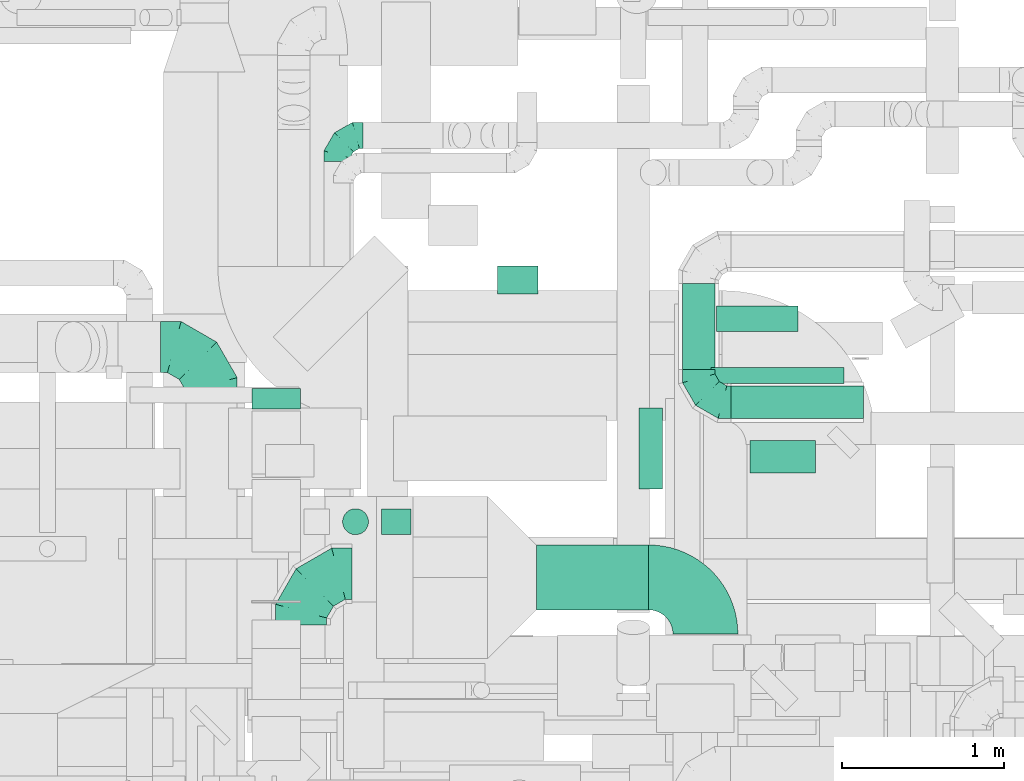
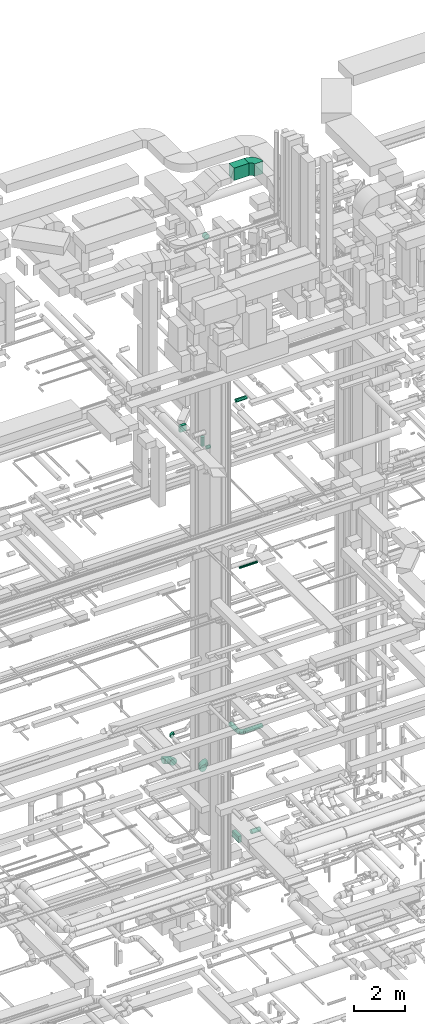
# One storey, part 279 of 337: 11 flow segments, 5 flow fittings.
"""IFC2X3 building model written with IfcOpenShell, lengths in millimetres."""

from ifc_helpers import new_model, entity, si_unit, converted_unit, derived_unit, direction, frame, frame_2d, origin, origin_2d_with_axis, place, context, subcontext, project, spatial, polyline, circle_curve, parameter, trimmed, segment, composite_curve, rectangle, circle, outline, extrude, faceted_brep, source, transform, mapped, material, type_object, type_shapes, element, save


model = new_model("IFC2X3")

# Units and contexts
model_context = context("Model", 3, precision=0.01, world=origin(), true_north=direction((6.12303176911189e-17, 1.0)))
body_context = subcontext(model_context, "Body", "Model", "MODEL_VIEW")
ifc_project = project(units=[si_unit("LENGTHUNIT", "METRE", prefix="MILLI"), si_unit("AREAUNIT", "SQUARE_METRE"), si_unit("VOLUMEUNIT", "CUBIC_METRE"), converted_unit("PLANEANGLEUNIT", "DEGREE", entity("IfcRatioMeasure", 0.0174532925199433), si_unit("PLANEANGLEUNIT", "RADIAN"), dimensions=[0, 0, 0, 0, 0, 0, 0]), si_unit("MASSUNIT", "GRAM", prefix="KILO"), derived_unit("MASSDENSITYUNIT", [(si_unit("MASSUNIT", "GRAM", prefix="KILO"), 1), (si_unit("LENGTHUNIT", "METRE"), -3)]), derived_unit("MOMENTOFINERTIAUNIT", [(si_unit("LENGTHUNIT", "METRE"), 4)]), si_unit("TIMEUNIT", "SECOND"), si_unit("FREQUENCYUNIT", "HERTZ"), si_unit("THERMODYNAMICTEMPERATUREUNIT", "DEGREE_CELSIUS"), derived_unit("THERMALTRANSMITTANCEUNIT", [(si_unit("MASSUNIT", "GRAM", prefix="KILO"), 1), (si_unit("THERMODYNAMICTEMPERATUREUNIT", "KELVIN"), -1), (si_unit("TIMEUNIT", "SECOND"), -3)]), derived_unit("VOLUMETRICFLOWRATEUNIT", [(si_unit("LENGTHUNIT", "METRE"), 3), (si_unit("TIMEUNIT", "SECOND"), -1)]), derived_unit("MASSFLOWRATEUNIT", [(si_unit("MASSUNIT", "GRAM", prefix="KILO"), 1), (si_unit("TIMEUNIT", "SECOND"), -1)]), derived_unit("ROTATIONALFREQUENCYUNIT", [(si_unit("TIMEUNIT", "SECOND"), -1)]), si_unit("ELECTRICCURRENTUNIT", "AMPERE"), si_unit("ELECTRICVOLTAGEUNIT", "VOLT"), si_unit("POWERUNIT", "WATT"), si_unit("FORCEUNIT", "NEWTON", prefix="KILO"), si_unit("ILLUMINANCEUNIT", "LUX"), si_unit("LUMINOUSFLUXUNIT", "LUMEN"), si_unit("LUMINOUSINTENSITYUNIT", "CANDELA"), derived_unit("USERDEFINED", [(si_unit("MASSUNIT", "GRAM", prefix="KILO"), -1), (si_unit("LENGTHUNIT", "METRE"), -2), (si_unit("TIMEUNIT", "SECOND"), 3), (si_unit("LUMINOUSFLUXUNIT", "LUMEN"), 1)]), derived_unit("LINEARVELOCITYUNIT", [(si_unit("LENGTHUNIT", "METRE"), 1), (si_unit("TIMEUNIT", "SECOND"), -1)]), si_unit("PRESSUREUNIT", "PASCAL"), derived_unit("USERDEFINED", [(si_unit("LENGTHUNIT", "METRE"), -2), (si_unit("MASSUNIT", "GRAM", prefix="KILO"), 1), (si_unit("TIMEUNIT", "SECOND"), -2)]), derived_unit("LINEARFORCEUNIT", [(si_unit("MASSUNIT", "GRAM", prefix="KILO"), 1), (si_unit("LENGTHUNIT", "METRE"), 1), (si_unit("TIMEUNIT", "SECOND"), -2), (si_unit("LENGTHUNIT", "METRE"), -1)]), derived_unit("PLANARFORCEUNIT", [(si_unit("MASSUNIT", "GRAM", prefix="KILO"), 1), (si_unit("LENGTHUNIT", "METRE"), 1), (si_unit("TIMEUNIT", "SECOND"), -2), (si_unit("LENGTHUNIT", "METRE"), -2)])], contexts=[model_context])

# Site, building, storey
site_placement = place(None, origin())
site = spatial("IfcSite", under=ifc_project, at=site_placement, CompositionType="ELEMENT")
building_placement = place(site_placement, origin())
building = spatial("IfcBuilding", under=site, at=building_placement, CompositionType="ELEMENT")
storey_placement = place(building_placement, origin())
storey = spatial("IfcBuildingStorey", under=building, at=storey_placement, CompositionType="ELEMENT", Elevation=0.0)

# Flow segments
duct_segment_type_1 = type_object("IfcDuctSegmentType", PredefinedType="NOTDEFINED")
flow_segment_1_placement = place(storey_placement, frame((49005.89, 16499.25, -1275.0)))
element("IfcFlowSegment", 1, at=flow_segment_1_placement, inside=storey, type_object=duct_segment_type_1, context=body_context, shape_type="SweptSolid", body=[
    extrude(rectangle(XDim=143.434564349726, YDim=500.000000000001, at=origin_2d_with_axis()), frame((71.72, 250.0, 0.0), z_axis=(0.0, 0.0, 1.0), x_axis=(-1.0, 0.0, 0.0)), (0.0, 0.0, 1.0), 300.0),
])
flow_segment_2_placement = place(storey_placement, frame((46619.03, 16991.28, 19020.0)))
element("IfcFlowSegment", 2, at=flow_segment_2_placement, inside=storey, type_object=duct_segment_type_1, context=body_context, shape_type="SweptSolid", body=[
    extrude(rectangle(XDim=127.913564567193, YDim=300.000000000001, at=origin_2d_with_axis()), frame((150.0, 63.96, 0.0), z_axis=(0.0, 0.0, 1.0), x_axis=(0.0, 1.0, 0.0)), (0.0, 0.0, 1.0), 300.000000000001),
])
flow_segment_3_placement = place(storey_placement, frame((48372.03, 15754.64, 31300.0)))
element("IfcFlowSegment", 3, at=flow_segment_3_placement, inside=storey, type_object=duct_segment_type_1, context=body_context, shape_type="SweptSolid", body=[
    extrude(rectangle(XDim=692.725346598004, YDim=400.0, at=origin_2d_with_axis()), frame((346.36, 200.0, 0.0), z_axis=(0.0, 0.0, 1.0), x_axis=(-1.0, 0.0, 0.0)), (0.0, 0.0, 1.0), 600.000000000002),
])
duct_segment_type_2 = type_object("IfcDuctSegmentType", PredefinedType="NOTDEFINED")
flow_segment_4_placement = place(storey_placement, frame((49689.33, 16597.29, -1201.6)))
element("IfcFlowSegment", 4, at=flow_segment_4_placement, inside=storey, type_object=duct_segment_type_2, context=body_context, shape_type="SweptSolid", body=[
    extrude(circle(Radius=100.0, at=origin_2d_with_axis()), frame((0.0, 101.6, 101.6), z_axis=(1.0, 0.0, 0.0), x_axis=(0.0, 1.0, 0.0)), (0.0, 0.0, 1.0), 405.08393606875),
])
flow_segment_5_placement = place(storey_placement, frame((49450.04, 17147.64, 11348.4)))
element("IfcFlowSegment", 5, at=flow_segment_5_placement, inside=storey, type_object=duct_segment_type_2, context=body_context, shape_type="SweptSolid", body=[
    extrude(circle(Radius=50.0, at=origin_2d_with_axis()), frame((0.0, 51.6, 51.6), z_axis=(1.0, 0.0, 0.0), x_axis=(0.0, 1.0, 0.0)), (0.0, 0.0, 1.0), 820.000000000021),
])
flow_segment_6_placement = place(storey_placement, frame((47418.09, 16216.25, 18368.4)))
element("IfcFlowSegment", 6, at=flow_segment_6_placement, inside=storey, type_object=duct_segment_type_2, context=body_context, shape_type="SweptSolid", body=[
    extrude(circle(Radius=80.0, at=origin_2d_with_axis()), frame((0.0, 81.6, 81.6), z_axis=(1.0, 0.0, 0.0), x_axis=(0.0, -1.0, 0.0)), (0.0, 0.0, 1.0), 180.937499999975),
])
flow_segment_7_placement = place(storey_placement, frame((49482.84, 17467.47, 19143.4)))
element("IfcFlowSegment", 7, at=flow_segment_7_placement, inside=storey, type_object=duct_segment_type_2, context=body_context, shape_type="SweptSolid", body=[
    extrude(circle(Radius=80.0, at=origin_2d_with_axis()), frame((0.0, 81.6, 81.6), z_axis=(1.0, 0.0, 0.0), x_axis=(0.0, -1.0, 0.0)), (0.0, 0.0, 1.0), 502.500000000068),
])
flow_segment_8_placement = place(storey_placement, frame((47176.49, 16216.25, 18610.0)))
element("IfcFlowSegment", 8, at=flow_segment_8_placement, inside=storey, type_object=duct_segment_type_2, context=body_context, shape_type="SweptSolid", body=[
    extrude(circle(Radius=80.0, at=origin_2d_with_axis()), frame((81.6, 81.6, 0.0), z_axis=(0.0, 0.0, 1.0), x_axis=(-1.0, 0.0, 0.0)), (0.0, 0.0, 1.0), 430.000000000011),
])
flow_segment_9_placement = place(storey_placement, frame((48132.33, 17701.6, 27323.4)))
element("IfcFlowSegment", 9, at=flow_segment_9_placement, inside=storey, type_object=duct_segment_type_2, context=body_context, shape_type="SweptSolid", body=[
    extrude(circle(Radius=125.0, at=origin_2d_with_axis()), frame((126.6, 0.0, 126.6), z_axis=(0.0, 1.0, 0.0), x_axis=(-1.0, 0.0, 0.0)), (0.0, 0.0, 1.0), 173.750000000006),
])
duct_segment_type_3 = type_object("IfcDuctSegmentType", PredefinedType="NOTDEFINED")
flow_segment_10_placement = place(storey_placement, frame((49271.67, 17235.07, 3478.4)))
element("IfcFlowSegment", 10, at=flow_segment_10_placement, inside=storey, type_object=duct_segment_type_3, context=body_context, shape_type="SweptSolid", body=[
    extrude(circle(Radius=100.0, at=origin_2d_with_axis()), frame((101.6, 0.0, 101.6), z_axis=(0.0, 1.0, 0.0), x_axis=(-1.0, 0.0, 0.0)), (0.0, 0.0, 1.0), 530.000000000001),
])
flow_segment_11_placement = place(storey_placement, frame((49573.27, 16933.48, 3478.4)))
element("IfcFlowSegment", 11, at=flow_segment_11_placement, inside=storey, type_object=duct_segment_type_3, context=body_context, shape_type="SweptSolid", body=[
    extrude(circle(Radius=100.0, at=origin_2d_with_axis()), frame((0.0, 101.6, 101.6), z_axis=(1.0, 0.0, 0.0), x_axis=(0.0, -1.0, 0.0)), (0.0, 0.0, 1.0), 815.000000000005),
])

# Flow fittings
ifc_material = material()
duct_fitting_type_1 = type_object("IfcDuctFittingType", PredefinedType="NOTDEFINED", material=ifc_material)
shared_shape_1 = source(origin(), body_context, "Body", "Brep", [
    faceted_brep([(-160.0, 0.0, -80.0), (-160.0, -20.71, -77.27), (-160.0, -40.0, -69.28), (-160.0, -56.57, -56.57), (-160.0, -69.28, -40.0), (-160.0, -77.27, -20.71), (-160.0, -80.0, 0.0), (-160.0, -77.27, 20.71), (-160.0, -69.28, 40.0), (-160.0, -56.57, 56.57), (-160.0, -40.0, 69.28), (-160.0, -20.71, 77.27), (-160.0, 0.0, 80.0), (-160.0, 20.71, 77.27), (-160.0, 40.0, 69.28), (-160.0, 56.57, 56.57), (-160.0, 69.28, 40.0), (-160.0, 77.27, 20.71), (-160.0, 80.0, 0.0), (-160.0, 77.27, -20.71), (-160.0, 69.28, -40.0), (-160.0, 56.57, -56.57), (-160.0, 40.0, -69.28), (-160.0, 20.71, -77.27), (-122.68, 20.71, 77.27), (-127.85, 40.0, 69.28), (-117.13, 0.0, 80.0), (-132.29, 56.57, 56.57), (-137.83, 77.27, 20.71), (-138.56, 80.0, 0.0), (-135.69, 69.28, 40.0), (-135.69, 69.28, -40.0), (-132.29, 56.57, -56.57), (-137.83, 77.27, -20.71), (-122.68, 20.71, -77.27), (-117.13, 0.0, -80.0), (-127.85, 40.0, -69.28), (-111.58, -20.71, -77.27), (-106.41, -40.0, -69.28), (-101.97, -56.57, -56.57), (-98.56, -69.28, -40.0), (-96.42, -77.27, -20.71), (-95.69, -80.0, 0.0), (-96.42, -77.27, 20.71), (-98.56, -69.28, 40.0), (-101.97, -56.57, 56.57), (-106.41, -40.0, 69.28), (-111.58, -20.71, 77.27), (-58.03, 58.03, 77.27), (-72.15, 72.15, 69.28), (-42.87, 42.87, 80.0), (-84.28, 84.28, 56.57), (-93.59, 93.59, 40.0), (-99.44, 99.44, 20.71), (-101.44, 101.44, 0.0), (-99.44, 99.44, -20.71), (-93.59, 93.59, -40.0), (-84.28, 84.28, -56.57), (-58.03, 58.03, -77.27), (-42.87, 42.87, -80.0), (-72.15, 72.15, -69.28), (-27.71, 27.71, -77.27), (-13.59, 13.59, -69.28), (-1.46, 1.46, -56.57), (7.85, -7.85, -40.0), (13.7, -13.7, -20.71), (15.69, -15.69, 0.0), (13.7, -13.7, 20.71), (7.85, -7.85, 40.0), (-1.46, 1.46, 56.57), (-13.59, 13.59, 69.28), (-27.71, 27.71, 77.27), (-20.71, 122.68, 77.27), (-40.0, 127.85, 69.28), (0.0, 117.13, 80.0), (-56.57, 132.29, 56.57), (-69.28, 135.69, 40.0), (-77.27, 137.83, 20.71), (-80.0, 138.56, 0.0), (-77.27, 137.83, -20.71), (-69.28, 135.69, -40.0), (-56.57, 132.29, -56.57), (-20.71, 122.68, -77.27), (0.0, 117.13, -80.0), (-40.0, 127.85, -69.28), (20.71, 111.58, -77.27), (40.0, 106.41, -69.28), (56.57, 101.97, -56.57), (69.28, 98.56, -40.0), (77.27, 96.42, -20.71), (80.0, 95.69, 0.0), (77.27, 96.42, 20.71), (69.28, 98.56, 40.0), (56.57, 101.97, 56.57), (40.0, 106.41, 69.28), (20.71, 111.58, 77.27), (-20.71, 160.0, -77.27), (-40.0, 160.0, -69.28), (-56.57, 160.0, -56.57), (-69.28, 160.0, -40.0), (-77.27, 160.0, -20.71), (-80.0, 160.0, 0.0), (-77.27, 160.0, 20.71), (-69.28, 160.0, 40.0), (-56.57, 160.0, 56.57), (-40.0, 160.0, 69.28), (-20.71, 160.0, 77.27), (0.0, 160.0, 80.0), (20.71, 160.0, 77.27), (40.0, 160.0, 69.28), (56.57, 160.0, 56.57), (69.28, 160.0, 40.0), (77.27, 160.0, 20.71), (80.0, 160.0, 0.0), (77.27, 160.0, -20.71), (69.28, 160.0, -40.0), (56.57, 160.0, -56.57), (40.0, 160.0, -69.28), (20.71, 160.0, -77.27), (0.0, 160.0, -80.0)], [[[0, 1, 2, 3, 4, 5, 6, 7, 8, 9, 10, 11, 12, 13, 14, 15, 16, 17, 18, 19, 20, 21, 22, 23]], [[24, 25, 14, 13]], [[26, 24, 13, 12]], [[14, 25, 27, 15]], [[28, 29, 18, 17]], [[30, 28, 17, 16]], [[15, 27, 30, 16]], [[20, 31, 32, 21]], [[33, 31, 20, 19]], [[18, 29, 33, 19]], [[34, 35, 0, 23]], [[36, 34, 23, 22]], [[32, 36, 22, 21]], [[1, 0, 35, 37]], [[2, 1, 37, 38]], [[3, 2, 38, 39]], [[5, 4, 40, 41]], [[6, 5, 41, 42]], [[39, 40, 4, 3]], [[6, 42, 43, 7]], [[7, 43, 44, 8]], [[8, 44, 45, 9]], [[9, 45, 46, 10]], [[10, 46, 47, 11]], [[26, 12, 11, 47]], [[48, 49, 25, 24]], [[50, 48, 24, 26]], [[27, 25, 49, 51]], [[52, 53, 28, 30]], [[51, 52, 30, 27]], [[29, 28, 53, 54]], [[55, 56, 31, 33]], [[54, 55, 33, 29]], [[32, 31, 56, 57]], [[58, 59, 35, 34]], [[60, 58, 34, 36]], [[57, 60, 36, 32]], [[37, 35, 59, 61]], [[38, 37, 61, 62]], [[39, 38, 62, 63]], [[41, 40, 64, 65]], [[42, 41, 65, 66]], [[63, 64, 40, 39]], [[43, 42, 66, 67]], [[44, 43, 67, 68]], [[68, 69, 45, 44]], [[46, 45, 69, 70]], [[47, 46, 70, 71]], [[26, 47, 71, 50]], [[72, 73, 49, 48]], [[74, 72, 48, 50]], [[51, 49, 73, 75]], [[76, 77, 53, 52]], [[75, 76, 52, 51]], [[54, 53, 77, 78]], [[79, 80, 56, 55]], [[78, 79, 55, 54]], [[57, 56, 80, 81]], [[82, 83, 59, 58]], [[84, 82, 58, 60]], [[81, 84, 60, 57]], [[61, 59, 83, 85]], [[62, 61, 85, 86]], [[63, 62, 86, 87]], [[65, 64, 88, 89]], [[66, 65, 89, 90]], [[87, 88, 64, 63]], [[67, 66, 90, 91]], [[68, 67, 91, 92]], [[92, 93, 69, 68]], [[70, 69, 93, 94]], [[71, 70, 94, 95]], [[50, 71, 95, 74]], [[96, 97, 98, 99, 100, 101, 102, 103, 104, 105, 106, 107, 108, 109, 110, 111, 112, 113, 114, 115, 116, 117, 118, 119]], [[72, 74, 107, 106]], [[73, 72, 106, 105]], [[75, 73, 105, 104]], [[77, 76, 103, 102]], [[78, 77, 102, 101]], [[75, 104, 103, 76]], [[78, 101, 100, 79]], [[79, 100, 99, 80]], [[80, 99, 98, 81]], [[84, 97, 96, 82]], [[82, 96, 119, 83]], [[84, 81, 98, 97]], [[118, 117, 86, 85]], [[119, 118, 85, 83]], [[116, 87, 86, 117]], [[88, 115, 114, 89]], [[89, 114, 113, 90]], [[115, 88, 87, 116]], [[112, 111, 92, 91]], [[113, 112, 91, 90]], [[111, 110, 93, 92]], [[95, 94, 109, 108]], [[74, 95, 108, 107]], [[110, 109, 94, 93]]]),
])
type_shapes(duct_fitting_type_1, [shared_shape_1])
flow_fitting_1_placement = place(storey_placement, frame((47143.34, 18679.11, 3280.0), z_axis=(0.0, 0.0, 1.0), x_axis=(-1.0, 0.0, 0.0)))
element("IfcFlowFitting", 12, at=flow_fitting_1_placement, inside=storey, type_object=duct_fitting_type_1, material=ifc_material, context=body_context, shape_type="MappedRepresentation", body=[
    mapped(shared_shape_1, transform((0.0, 0.0, 0.0), scale=1.0)),
])
duct_fitting_type_2 = type_object("IfcDuctFittingType", PredefinedType="NOTDEFINED", material=ifc_material)
shared_shape_2 = source(origin(), body_context, "Body", "Brep", [
    faceted_brep([(-200.0, 0.0, -100.0), (-200.0, -25.88, -96.59), (-200.0, -50.0, -86.6), (-200.0, -70.71, -70.71), (-200.0, -86.6, -50.0), (-200.0, -96.59, -25.88), (-200.0, -100.0, 0.0), (-200.0, -96.59, 25.88), (-200.0, -86.6, 50.0), (-200.0, -70.71, 70.71), (-200.0, -50.0, 86.6), (-200.0, -25.88, 96.59), (-200.0, 0.0, 100.0), (-200.0, 25.88, 96.59), (-200.0, 50.0, 86.6), (-200.0, 70.71, 70.71), (-200.0, 86.6, 50.0), (-200.0, 96.59, 25.88), (-200.0, 100.0, 0.0), (-200.0, 96.59, -25.88), (-200.0, 86.6, -50.0), (-200.0, 70.71, -70.71), (-200.0, 50.0, -86.6), (-200.0, 25.88, -96.59), (-153.35, 25.88, 96.59), (-159.81, 50.0, 86.6), (-146.41, 0.0, 100.0), (-165.36, 70.71, 70.71), (-172.29, 96.59, 25.88), (-173.21, 100.0, 0.0), (-169.62, 86.6, 50.0), (-169.62, 86.6, -50.0), (-165.36, 70.71, -70.71), (-172.29, 96.59, -25.88), (-153.35, 25.88, -96.59), (-146.41, 0.0, -100.0), (-159.81, 50.0, -86.6), (-139.48, -25.88, -96.59), (-133.01, -50.0, -86.6), (-127.46, -70.71, -70.71), (-123.21, -86.6, -50.0), (-120.53, -96.59, -25.88), (-119.62, -100.0, 0.0), (-120.53, -96.59, 25.88), (-123.21, -86.6, 50.0), (-127.46, -70.71, 70.71), (-133.01, -50.0, 86.6), (-139.48, -25.88, 96.59), (-72.54, 72.54, 96.59), (-90.19, 90.19, 86.6), (-53.59, 53.59, 100.0), (-105.35, 105.35, 70.71), (-116.99, 116.99, 50.0), (-124.3, 124.3, 25.88), (-126.79, 126.79, 0.0), (-124.3, 124.3, -25.88), (-116.99, 116.99, -50.0), (-105.35, 105.35, -70.71), (-72.54, 72.54, -96.59), (-53.59, 53.59, -100.0), (-90.19, 90.19, -86.6), (-34.64, 34.64, -96.59), (-16.99, 16.99, -86.6), (-1.83, 1.83, -70.71), (9.81, -9.81, -50.0), (17.12, -17.12, -25.88), (19.62, -19.62, 0.0), (17.12, -17.12, 25.88), (9.81, -9.81, 50.0), (-1.83, 1.83, 70.71), (-16.99, 16.99, 86.6), (-34.64, 34.64, 96.59), (-25.88, 153.35, 96.59), (-50.0, 159.81, 86.6), (0.0, 146.41, 100.0), (-70.71, 165.36, 70.71), (-86.6, 169.62, 50.0), (-96.59, 172.29, 25.88), (-100.0, 173.21, 0.0), (-96.59, 172.29, -25.88), (-86.6, 169.62, -50.0), (-70.71, 165.36, -70.71), (-25.88, 153.35, -96.59), (0.0, 146.41, -100.0), (-50.0, 159.81, -86.6), (25.88, 139.48, -96.59), (50.0, 133.01, -86.6), (70.71, 127.46, -70.71), (86.6, 123.21, -50.0), (96.59, 120.53, -25.88), (100.0, 119.62, 0.0), (96.59, 120.53, 25.88), (86.6, 123.21, 50.0), (70.71, 127.46, 70.71), (50.0, 133.01, 86.6), (25.88, 139.48, 96.59), (-25.88, 200.0, -96.59), (-50.0, 200.0, -86.6), (-70.71, 200.0, -70.71), (-86.6, 200.0, -50.0), (-96.59, 200.0, -25.88), (-100.0, 200.0, 0.0), (-96.59, 200.0, 25.88), (-86.6, 200.0, 50.0), (-70.71, 200.0, 70.71), (-50.0, 200.0, 86.6), (-25.88, 200.0, 96.59), (0.0, 200.0, 100.0), (25.88, 200.0, 96.59), (50.0, 200.0, 86.6), (70.71, 200.0, 70.71), (86.6, 200.0, 50.0), (96.59, 200.0, 25.88), (100.0, 200.0, 0.0), (96.59, 200.0, -25.88), (86.6, 200.0, -50.0), (70.71, 200.0, -70.71), (50.0, 200.0, -86.6), (25.88, 200.0, -96.59), (0.0, 200.0, -100.0)], [[[0, 1, 2, 3, 4, 5, 6, 7, 8, 9, 10, 11, 12, 13, 14, 15, 16, 17, 18, 19, 20, 21, 22, 23]], [[24, 25, 14, 13]], [[26, 24, 13, 12]], [[14, 25, 27, 15]], [[28, 29, 18, 17]], [[30, 28, 17, 16]], [[15, 27, 30, 16]], [[20, 31, 32, 21]], [[33, 31, 20, 19]], [[18, 29, 33, 19]], [[34, 35, 0, 23]], [[36, 34, 23, 22]], [[32, 36, 22, 21]], [[1, 0, 35, 37]], [[2, 1, 37, 38]], [[38, 39, 3, 2]], [[5, 4, 40, 41]], [[6, 5, 41, 42]], [[39, 40, 4, 3]], [[6, 42, 43, 7]], [[7, 43, 44, 8]], [[8, 44, 45, 9]], [[9, 45, 46, 10]], [[10, 46, 47, 11]], [[26, 12, 11, 47]], [[48, 49, 25, 24]], [[50, 48, 24, 26]], [[27, 25, 49, 51]], [[52, 53, 28, 30]], [[51, 52, 30, 27]], [[29, 28, 53, 54]], [[55, 56, 31, 33]], [[54, 55, 33, 29]], [[32, 31, 56, 57]], [[58, 59, 35, 34]], [[60, 58, 34, 36]], [[57, 60, 36, 32]], [[37, 35, 59, 61]], [[38, 37, 61, 62]], [[39, 38, 62, 63]], [[41, 40, 64, 65]], [[42, 41, 65, 66]], [[63, 64, 40, 39]], [[43, 42, 66, 67]], [[44, 43, 67, 68]], [[68, 69, 45, 44]], [[46, 45, 69, 70]], [[47, 46, 70, 71]], [[26, 47, 71, 50]], [[72, 73, 49, 48]], [[74, 72, 48, 50]], [[51, 49, 73, 75]], [[76, 77, 53, 52]], [[75, 76, 52, 51]], [[54, 53, 77, 78]], [[79, 80, 56, 55]], [[78, 79, 55, 54]], [[57, 56, 80, 81]], [[82, 83, 59, 58]], [[84, 82, 58, 60]], [[81, 84, 60, 57]], [[61, 59, 83, 85]], [[62, 61, 85, 86]], [[63, 62, 86, 87]], [[65, 64, 88, 89]], [[66, 65, 89, 90]], [[87, 88, 64, 63]], [[67, 66, 90, 91]], [[68, 67, 91, 92]], [[92, 93, 69, 68]], [[70, 69, 93, 94]], [[71, 70, 94, 95]], [[50, 71, 95, 74]], [[96, 97, 98, 99, 100, 101, 102, 103, 104, 105, 106, 107, 108, 109, 110, 111, 112, 113, 114, 115, 116, 117, 118, 119]], [[72, 74, 107, 106]], [[73, 72, 106, 105]], [[75, 73, 105, 104]], [[102, 101, 78, 77]], [[103, 102, 77, 76]], [[75, 104, 103, 76]], [[78, 101, 100, 79]], [[79, 100, 99, 80]], [[80, 99, 98, 81]], [[84, 97, 96, 82]], [[82, 96, 119, 83]], [[84, 81, 98, 97]], [[118, 117, 86, 85]], [[119, 118, 85, 83]], [[116, 87, 86, 117]], [[88, 115, 114, 89]], [[89, 114, 113, 90]], [[115, 88, 87, 116]], [[91, 90, 113, 112]], [[92, 91, 112, 111]], [[111, 110, 93, 92]], [[95, 94, 109, 108]], [[74, 95, 108, 107]], [[110, 109, 94, 93]]]),
])
type_shapes(duct_fitting_type_2, [shared_shape_2])
flow_fitting_2_placement = place(storey_placement, frame((49373.27, 17035.07, 3580.0), z_axis=(0.0, 0.0, 1.0), x_axis=(0.0, -1.0, 0.0)))
element("IfcFlowFitting", 13, at=flow_fitting_2_placement, inside=storey, type_object=duct_fitting_type_2, material=ifc_material, context=body_context, shape_type="MappedRepresentation", body=[
    mapped(shared_shape_2, transform((0.0, 0.0, 0.0), scale=1.0)),
])
duct_fitting_type_3 = type_object("IfcDuctFittingType", PredefinedType="NOTDEFINED", material=ifc_material)
shared_shape_3 = source(origin(), body_context, "Body", "Brep", [
    faceted_brep([(-315.0, 0.0, -157.5), (-315.0, -40.76, -152.13), (-315.0, -78.75, -136.4), (-315.0, -111.37, -111.37), (-315.0, -136.4, -78.75), (-315.0, -152.13, -40.76), (-315.0, -157.5, 0.0), (-315.0, -152.13, 40.76), (-315.0, -136.4, 78.75), (-315.0, -111.37, 111.37), (-315.0, -78.75, 136.4), (-315.0, -40.76, 152.13), (-315.0, 0.0, 157.5), (-315.0, 40.76, 152.13), (-315.0, 78.75, 136.4), (-315.0, 111.37, 111.37), (-315.0, 136.4, 78.75), (-315.0, 152.13, 40.76), (-315.0, 157.5, 0.0), (-315.0, 152.13, -40.76), (-315.0, 136.4, -78.75), (-315.0, 111.37, -111.37), (-315.0, 78.75, -136.4), (-315.0, 40.76, -152.13), (-241.52, 40.76, 152.13), (-251.7, 78.75, 136.4), (-230.6, 0.0, 157.5), (-260.44, 111.37, 111.37), (-271.36, 152.13, 40.76), (-272.8, 157.5, 0.0), (-267.14, 136.4, 78.75), (-267.14, 136.4, -78.75), (-260.44, 111.37, -111.37), (-271.36, 152.13, -40.76), (-241.52, 40.76, -152.13), (-230.6, 0.0, -157.5), (-251.7, 78.75, -136.4), (-219.67, -40.76, -152.13), (-209.5, -78.75, -136.4), (-200.75, -111.37, -111.37), (-194.05, -136.4, -78.75), (-189.83, -152.13, -40.76), (-188.39, -157.5, 0.0), (-189.83, -152.13, 40.76), (-194.05, -136.4, 78.75), (-200.75, -111.37, 111.37), (-209.5, -78.75, 136.4), (-219.67, -40.76, 152.13), (-114.25, 114.25, 152.13), (-142.05, 142.05, 136.4), (-84.4, 84.4, 157.5), (-165.93, 165.93, 111.37), (-184.25, 184.25, 78.75), (-195.77, 195.77, 40.76), (-199.7, 199.7, 0.0), (-195.77, 195.77, -40.76), (-184.25, 184.25, -78.75), (-165.93, 165.93, -111.37), (-114.25, 114.25, -152.13), (-84.4, 84.4, -157.5), (-142.05, 142.05, -136.4), (-54.56, 54.56, -152.13), (-26.75, 26.75, -136.4), (-2.88, 2.88, -111.37), (15.45, -15.45, -78.75), (26.97, -26.97, -40.76), (30.89, -30.89, 0.0), (26.97, -26.97, 40.76), (15.45, -15.45, 78.75), (-2.88, 2.88, 111.37), (-26.75, 26.75, 136.4), (-54.56, 54.56, 152.13), (-40.76, 241.52, 152.13), (-78.75, 251.7, 136.4), (0.0, 230.6, 157.5), (-111.37, 260.44, 111.37), (-136.4, 267.14, 78.75), (-152.13, 271.36, 40.76), (-157.5, 272.8, 0.0), (-152.13, 271.36, -40.76), (-136.4, 267.14, -78.75), (-111.37, 260.44, -111.37), (-40.76, 241.52, -152.13), (0.0, 230.6, -157.5), (-78.75, 251.7, -136.4), (40.76, 219.67, -152.13), (78.75, 209.5, -136.4), (111.37, 200.75, -111.37), (136.4, 194.05, -78.75), (152.13, 189.83, -40.76), (157.5, 188.39, 0.0), (152.13, 189.83, 40.76), (136.4, 194.05, 78.75), (111.37, 200.75, 111.37), (78.75, 209.5, 136.4), (40.76, 219.67, 152.13), (-40.76, 315.0, -152.13), (-78.75, 315.0, -136.4), (-111.37, 315.0, -111.37), (-136.4, 315.0, -78.75), (-152.13, 315.0, -40.76), (-157.5, 315.0, 0.0), (-152.13, 315.0, 40.76), (-136.4, 315.0, 78.75), (-111.37, 315.0, 111.37), (-78.75, 315.0, 136.4), (-40.76, 315.0, 152.13), (0.0, 315.0, 157.5), (40.76, 315.0, 152.13), (78.75, 315.0, 136.4), (111.37, 315.0, 111.37), (136.4, 315.0, 78.75), (152.13, 315.0, 40.76), (157.5, 315.0, 0.0), (152.13, 315.0, -40.76), (136.4, 315.0, -78.75), (111.37, 315.0, -111.37), (78.75, 315.0, -136.4), (40.76, 315.0, -152.13), (0.0, 315.0, -157.5)], [[[0, 1, 2, 3, 4, 5, 6, 7, 8, 9, 10, 11, 12, 13, 14, 15, 16, 17, 18, 19, 20, 21, 22, 23]], [[24, 25, 14, 13]], [[26, 24, 13, 12]], [[14, 25, 27, 15]], [[28, 29, 18, 17]], [[30, 28, 17, 16]], [[15, 27, 30, 16]], [[20, 31, 32, 21]], [[33, 31, 20, 19]], [[18, 29, 33, 19]], [[34, 35, 0, 23]], [[36, 34, 23, 22]], [[32, 36, 22, 21]], [[1, 0, 35, 37]], [[2, 1, 37, 38]], [[38, 39, 3, 2]], [[5, 4, 40, 41]], [[6, 5, 41, 42]], [[39, 40, 4, 3]], [[6, 42, 43, 7]], [[7, 43, 44, 8]], [[8, 44, 45, 9]], [[9, 45, 46, 10]], [[10, 46, 47, 11]], [[26, 12, 11, 47]], [[48, 49, 25, 24]], [[50, 48, 24, 26]], [[27, 25, 49, 51]], [[52, 53, 28, 30]], [[51, 52, 30, 27]], [[29, 28, 53, 54]], [[55, 56, 31, 33]], [[54, 55, 33, 29]], [[32, 31, 56, 57]], [[58, 59, 35, 34]], [[60, 58, 34, 36]], [[57, 60, 36, 32]], [[37, 35, 59, 61]], [[38, 37, 61, 62]], [[39, 38, 62, 63]], [[41, 40, 64, 65]], [[42, 41, 65, 66]], [[63, 64, 40, 39]], [[43, 42, 66, 67]], [[44, 43, 67, 68]], [[68, 69, 45, 44]], [[46, 45, 69, 70]], [[47, 46, 70, 71]], [[26, 47, 71, 50]], [[72, 73, 49, 48]], [[74, 72, 48, 50]], [[51, 49, 73, 75]], [[76, 77, 53, 52]], [[75, 76, 52, 51]], [[54, 53, 77, 78]], [[79, 80, 56, 55]], [[78, 79, 55, 54]], [[57, 56, 80, 81]], [[82, 83, 59, 58]], [[84, 82, 58, 60]], [[81, 84, 60, 57]], [[61, 59, 83, 85]], [[62, 61, 85, 86]], [[63, 62, 86, 87]], [[65, 64, 88, 89]], [[66, 65, 89, 90]], [[87, 88, 64, 63]], [[67, 66, 90, 91]], [[68, 67, 91, 92]], [[92, 93, 69, 68]], [[70, 69, 93, 94]], [[71, 70, 94, 95]], [[50, 71, 95, 74]], [[96, 97, 98, 99, 100, 101, 102, 103, 104, 105, 106, 107, 108, 109, 110, 111, 112, 113, 114, 115, 116, 117, 118, 119]], [[106, 105, 73, 72]], [[107, 106, 72, 74]], [[75, 73, 105, 104]], [[77, 76, 103, 102]], [[78, 77, 102, 101]], [[104, 103, 76, 75]], [[78, 101, 100, 79]], [[79, 100, 99, 80]], [[98, 81, 80, 99]], [[84, 97, 96, 82]], [[82, 96, 119, 83]], [[97, 84, 81, 98]], [[83, 119, 118, 85]], [[85, 118, 117, 86]], [[116, 87, 86, 117]], [[88, 115, 114, 89]], [[89, 114, 113, 90]], [[115, 88, 87, 116]], [[91, 90, 113, 112]], [[92, 91, 112, 111]], [[111, 110, 93, 92]], [[95, 94, 109, 108]], [[74, 95, 108, 107]], [[110, 109, 94, 93]]]),
])
type_shapes(duct_fitting_type_3, [shared_shape_3])
for number, where, z_axis, x_axis in (
    (14, (46922.72, 15977.42, 3549.99), (0.0, 0.0, 1.0), (-1.0, 0.0, 0.0)),
    (15, (46371.59, 17374.28, 3200.0), (0.0, 0.0, 1.0), (0.0, 1.0, 0.0)),
):
    element("IfcFlowFitting", number, at=place(storey_placement, frame(where, z_axis=z_axis, x_axis=x_axis)), inside=storey, type_object=duct_fitting_type_3, material=ifc_material, context=body_context, shape_type="MappedRepresentation", body=[
        mapped(shared_shape_3, transform((0.0, 0.0, 0.0), scale=1.0)),
    ])
duct_fitting_type_4 = type_object("IfcDuctFittingType", PredefinedType="NOTDEFINED", material=ifc_material)
shared_shape_4 = source(origin(), body_context, "Body", "SweptSolid", [
    extrude(outline(composite_curve([segment(polyline([(-375.0, -175.0), (25.0, -175.0)]), True, "CONTINUOUS"), segment(trimmed(circle_curve(frame_2d((175.0, -175.0), x_axis=(0.0, 1.0)), 150.0), [parameter(0.0)], [parameter(90.0000000000001)], True, "PARAMETER"), False, "CONTINUOUS"), segment(polyline([(175.0, -25.0), (175.0, 375.0)]), True, "CONTINUOUS"), segment(trimmed(circle_curve(frame_2d((175.0, -175.0), x_axis=(0.0, 1.0)), 550.0), [parameter(0.0)], [parameter(90.0)], True, "PARAMETER"), True, "CONTINUOUS")], self_intersect=False)), frame((-175.0, 175.0, -300.0), z_axis=(0.0, 0.0, 1.0), x_axis=(-1.0, 0.0, 0.0)), (0.0, 0.0, 1.0), 600.0),
])
type_shapes(duct_fitting_type_4, [shared_shape_4])
flow_fitting_3_placement = place(storey_placement, frame((49414.76, 15954.64, 31600.0), z_axis=(0.0, 0.0, 1.0), x_axis=(0.0, 1.0, 0.0)))
element("IfcFlowFitting", 16, at=flow_fitting_3_placement, inside=storey, type_object=duct_fitting_type_4, material=ifc_material, context=body_context, shape_type="MappedRepresentation", body=[
    mapped(shared_shape_4, transform((0.0, 0.0, 0.0), scale=1.0)),
])

save(model, "model.ifc")
